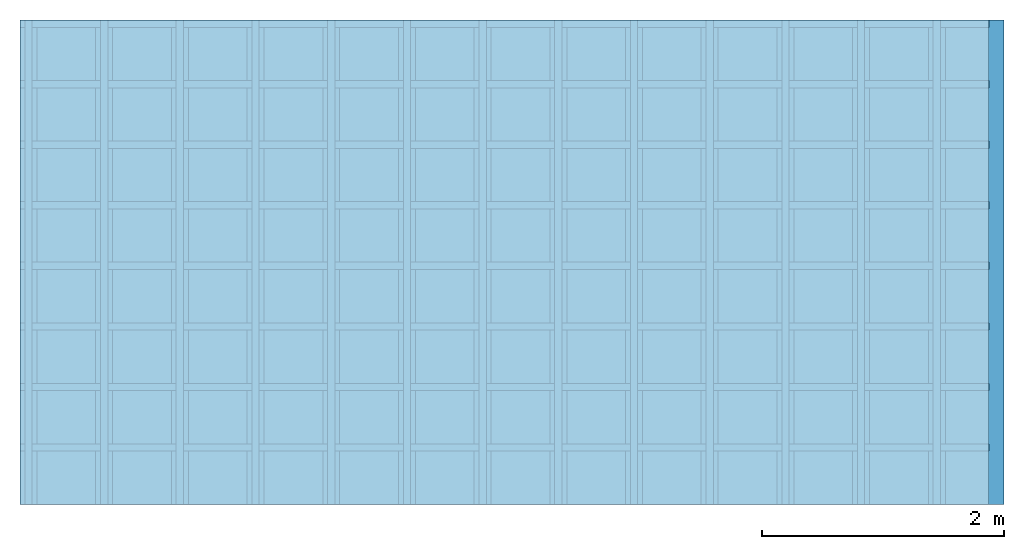
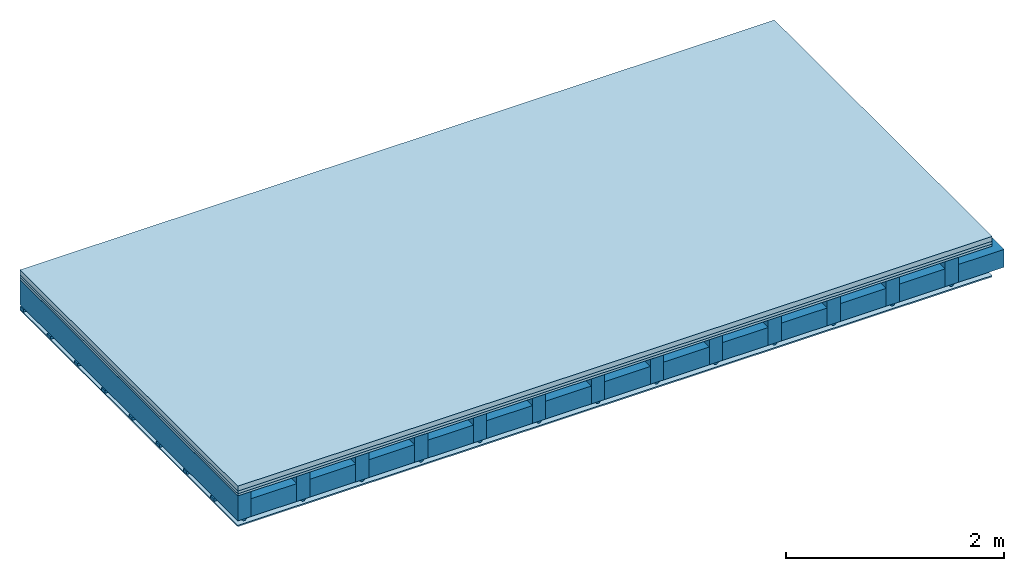
# One storey: 4 members, 4 plates, 1 element without a shape of its own.
"""IFC4 building model written with IfcOpenShell, lengths in metres."""

from ifc_helpers import new_model, si_unit, derived_unit, direction, frame, frame_2d, origin, origin_with_axes, place, context, project, spatial, polyline, rectangle, outline, extrude, material, layer, layer_set, type_object, element, aggregate, save


model = new_model("IFC4")

# Units and contexts
plan_context = context("Plan", 3, precision=1e-05, world=origin(), true_north=direction((0.0, 1.0)))
model_context = context("Model", 3, precision=1e-05, world=origin(), true_north=direction((0.0, 1.0)))
ifc_project = project(units=[si_unit("LENGTHUNIT", "METRE"), derived_unit("SOUNDPRESSUREUNIT", [(si_unit("PRESSUREUNIT", "PASCAL", prefix="MICRO"), 0)]), si_unit("ENERGYUNIT", "JOULE", prefix="MEGA"), si_unit("MASSUNIT", "GRAM", prefix="KILO"), derived_unit("THERMALTRANSMITTANCEUNIT", [(si_unit("POWERUNIT", "WATT"), 1), (si_unit("AREAUNIT", "SQUARE_METRE"), -1), (si_unit("THERMODYNAMICTEMPERATUREUNIT", "KELVIN"), -1)]), derived_unit("AREADENSITYUNIT", [(si_unit("MASSUNIT", "GRAM", prefix="KILO"), 1), (si_unit("AREAUNIT", "SQUARE_METRE"), -1)]), derived_unit("USERDEFINED", [(si_unit("ENERGYUNIT", "JOULE", prefix="MEGA"), 1), (si_unit("AREAUNIT", "SQUARE_METRE"), -1)])], contexts=[plan_context, model_context])

# Site, building, storey
site = spatial("IfcSite", under=ifc_project)
building_placement = place(None, origin())
building = spatial("IfcBuilding", under=site, at=building_placement)
storey_placement = place(building_placement, origin())
storey = spatial("IfcBuildingStorey", under=building, at=storey_placement)

# Slab, members, plates
ifc_material_1 = material(Category="04.005")
ifc_layer_1 = layer(ifc_material_1, 0.055, Name="On-material")
ifc_material_2 = material()
ifc_layer_2 = layer(ifc_material_2, 0.03, Name="Impact sound insulation")
ifc_material_3 = material(Category="07.001")
ifc_layer_3 = layer(ifc_material_3, 0.025, Name="Sub-floor")
ifc_material_4 = material(Name="of the art")
ifc_layer_4 = layer(ifc_material_4, 0.0, Name="Bond")
ifc_layer_5 = layer(None, 0.28, Name="Supporting structure")
ifc_material_5 = material(Name="no composite action")
ifc_layer_6 = layer(ifc_material_5, 0.0, Name="Bond")
ifc_layer_7 = layer(None, 0.02, Name="Coupling")
ifc_layer_8 = layer(None, 0.03, Name="Battens / profiles")
ifc_material_6 = material(Category="03.007")
ifc_layer_9 = layer(ifc_material_6, 0.015, Name="Ceiling covering 1st layer")
ifc_material_7 = material(Name="Glued joints")
ifc_layer_10 = layer(ifc_material_7, 0.0, Name="Surface / treatment")
ifc_layer_set = layer_set([ifc_layer_1, ifc_layer_2, ifc_layer_3, ifc_layer_4, ifc_layer_5, ifc_layer_6, ifc_layer_7, ifc_layer_8, ifc_layer_9, ifc_layer_10])
slab_type = type_object("IfcSlabType", Name="A0122", PredefinedType="NOTDEFINED", material=ifc_layer_set)
slab_placement = place(None, frame((0.0, 0.0, 0.0), z_axis=(0.0, 0.0, -1.0), x_axis=(1.0, 0.0, 0.0)))
slab = element("IfcSlab", 1, at=slab_placement, inside=storey, type_object=slab_type, material=ifc_layer_set, Name="Slab #1")
ifc_material_8 = material()
member_1_placement = place(slab_placement, origin())
member_1 = element("IfcMember", 2, at=member_1_placement, material=ifc_material_8, Name="Supporting structure", context=plan_context, shape_type="SweptSolid", body=[
    extrude(rectangle(XDim=0.14, YDim=0.28, at=frame_2d((0.07, 0.14), x_axis=(1.0, 0.0))), frame((0.0, 4.0, 0.11), z_axis=(0.0, -1.0, 0.0), x_axis=(1.0, 0.0, 0.0)), (0.0, 0.0, 1.0), 4.0),
    extrude(rectangle(XDim=0.14, YDim=0.28, at=frame_2d((0.07, 0.14), x_axis=(1.0, 0.0))), frame((0.625, 4.0, 0.11), z_axis=(0.0, -1.0, 0.0), x_axis=(1.0, 0.0, 0.0)), (0.0, 0.0, 1.0), 4.0),
    extrude(rectangle(XDim=0.14, YDim=0.28, at=frame_2d((0.07, 0.14), x_axis=(1.0, 0.0))), frame((1.25, 4.0, 0.11), z_axis=(0.0, -1.0, 0.0), x_axis=(1.0, 0.0, 0.0)), (0.0, 0.0, 1.0), 4.0),
    extrude(rectangle(XDim=0.14, YDim=0.28, at=frame_2d((0.07, 0.14), x_axis=(1.0, 0.0))), frame((1.875, 4.0, 0.11), z_axis=(0.0, -1.0, 0.0), x_axis=(1.0, 0.0, 0.0)), (0.0, 0.0, 1.0), 4.0),
    extrude(rectangle(XDim=0.14, YDim=0.28, at=frame_2d((0.07, 0.14), x_axis=(1.0, 0.0))), frame((2.5, 4.0, 0.11), z_axis=(0.0, -1.0, 0.0), x_axis=(1.0, 0.0, 0.0)), (0.0, 0.0, 1.0), 4.0),
    extrude(rectangle(XDim=0.14, YDim=0.28, at=frame_2d((0.07, 0.14), x_axis=(1.0, 0.0))), frame((3.125, 4.0, 0.11), z_axis=(0.0, -1.0, 0.0), x_axis=(1.0, 0.0, 0.0)), (0.0, 0.0, 1.0), 4.0),
    extrude(rectangle(XDim=0.14, YDim=0.28, at=frame_2d((0.07, 0.14), x_axis=(1.0, 0.0))), frame((3.75, 4.0, 0.11), z_axis=(0.0, -1.0, 0.0), x_axis=(1.0, 0.0, 0.0)), (0.0, 0.0, 1.0), 4.0),
    extrude(rectangle(XDim=0.14, YDim=0.28, at=frame_2d((0.07, 0.14), x_axis=(1.0, 0.0))), frame((4.375, 4.0, 0.11), z_axis=(0.0, -1.0, 0.0), x_axis=(1.0, 0.0, 0.0)), (0.0, 0.0, 1.0), 4.0),
    extrude(rectangle(XDim=0.14, YDim=0.28, at=frame_2d((0.07, 0.14), x_axis=(1.0, 0.0))), frame((5.0, 4.0, 0.11), z_axis=(0.0, -1.0, 0.0), x_axis=(1.0, 0.0, 0.0)), (0.0, 0.0, 1.0), 4.0),
    extrude(rectangle(XDim=0.14, YDim=0.28, at=frame_2d((0.07, 0.14), x_axis=(1.0, 0.0))), frame((5.625, 4.0, 0.11), z_axis=(0.0, -1.0, 0.0), x_axis=(1.0, 0.0, 0.0)), (0.0, 0.0, 1.0), 4.0),
    extrude(rectangle(XDim=0.14, YDim=0.28, at=frame_2d((0.07, 0.14), x_axis=(1.0, 0.0))), frame((6.25, 4.0, 0.11), z_axis=(0.0, -1.0, 0.0), x_axis=(1.0, 0.0, 0.0)), (0.0, 0.0, 1.0), 4.0),
    extrude(rectangle(XDim=0.14, YDim=0.28, at=frame_2d((0.07, 0.14), x_axis=(1.0, 0.0))), frame((6.875, 4.0, 0.11), z_axis=(0.0, -1.0, 0.0), x_axis=(1.0, 0.0, 0.0)), (0.0, 0.0, 1.0), 4.0),
    extrude(rectangle(XDim=0.14, YDim=0.28, at=frame_2d((0.07, 0.14), x_axis=(1.0, 0.0))), frame((7.5, 4.0, 0.11), z_axis=(0.0, -1.0, 0.0), x_axis=(1.0, 0.0, 0.0)), (0.0, 0.0, 1.0), 4.0),
])
ifc_material_9 = material()
member_2_placement = place(slab_placement, origin())
member_2 = element("IfcMember", 3, at=member_2_placement, material=ifc_material_9, Name="Cavity", context=plan_context, shape_type="SweptSolid", body=[
    extrude(rectangle(XDim=0.485, YDim=0.2, at=frame_2d((0.2425, 0.1), x_axis=(1.0, 0.0))), frame((0.14, 4.0, 0.19), z_axis=(0.0, -1.0, 0.0), x_axis=(1.0, 0.0, 0.0)), (0.0, 0.0, 1.0), 4.0),
    extrude(rectangle(XDim=0.485, YDim=0.2, at=frame_2d((0.2425, 0.1), x_axis=(1.0, 0.0))), frame((0.765, 4.0, 0.19), z_axis=(0.0, -1.0, 0.0), x_axis=(1.0, 0.0, 0.0)), (0.0, 0.0, 1.0), 4.0),
    extrude(rectangle(XDim=0.485, YDim=0.2, at=frame_2d((0.2425, 0.1), x_axis=(1.0, 0.0))), frame((1.39, 4.0, 0.19), z_axis=(0.0, -1.0, 0.0), x_axis=(1.0, 0.0, 0.0)), (0.0, 0.0, 1.0), 4.0),
    extrude(rectangle(XDim=0.485, YDim=0.2, at=frame_2d((0.2425, 0.1), x_axis=(1.0, 0.0))), frame((2.015, 4.0, 0.19), z_axis=(0.0, -1.0, 0.0), x_axis=(1.0, 0.0, 0.0)), (0.0, 0.0, 1.0), 4.0),
    extrude(rectangle(XDim=0.485, YDim=0.2, at=frame_2d((0.2425, 0.1), x_axis=(1.0, 0.0))), frame((2.64, 4.0, 0.19), z_axis=(0.0, -1.0, 0.0), x_axis=(1.0, 0.0, 0.0)), (0.0, 0.0, 1.0), 4.0),
    extrude(rectangle(XDim=0.485, YDim=0.2, at=frame_2d((0.2425, 0.1), x_axis=(1.0, 0.0))), frame((3.265, 4.0, 0.19), z_axis=(0.0, -1.0, 0.0), x_axis=(1.0, 0.0, 0.0)), (0.0, 0.0, 1.0), 4.0),
    extrude(rectangle(XDim=0.485, YDim=0.2, at=frame_2d((0.2425, 0.1), x_axis=(1.0, 0.0))), frame((3.89, 4.0, 0.19), z_axis=(0.0, -1.0, 0.0), x_axis=(1.0, 0.0, 0.0)), (0.0, 0.0, 1.0), 4.0),
    extrude(rectangle(XDim=0.485, YDim=0.2, at=frame_2d((0.2425, 0.1), x_axis=(1.0, 0.0))), frame((4.515, 4.0, 0.19), z_axis=(0.0, -1.0, 0.0), x_axis=(1.0, 0.0, 0.0)), (0.0, 0.0, 1.0), 4.0),
    extrude(rectangle(XDim=0.485, YDim=0.2, at=frame_2d((0.2425, 0.1), x_axis=(1.0, 0.0))), frame((5.14, 4.0, 0.19), z_axis=(0.0, -1.0, 0.0), x_axis=(1.0, 0.0, 0.0)), (0.0, 0.0, 1.0), 4.0),
    extrude(rectangle(XDim=0.485, YDim=0.2, at=frame_2d((0.2425, 0.1), x_axis=(1.0, 0.0))), frame((5.765, 4.0, 0.19), z_axis=(0.0, -1.0, 0.0), x_axis=(1.0, 0.0, 0.0)), (0.0, 0.0, 1.0), 4.0),
    extrude(rectangle(XDim=0.485, YDim=0.2, at=frame_2d((0.2425, 0.1), x_axis=(1.0, 0.0))), frame((6.39, 4.0, 0.19), z_axis=(0.0, -1.0, 0.0), x_axis=(1.0, 0.0, 0.0)), (0.0, 0.0, 1.0), 4.0),
    extrude(rectangle(XDim=0.485, YDim=0.2, at=frame_2d((0.2425, 0.1), x_axis=(1.0, 0.0))), frame((7.015, 4.0, 0.19), z_axis=(0.0, -1.0, 0.0), x_axis=(1.0, 0.0, 0.0)), (0.0, 0.0, 1.0), 4.0),
    extrude(rectangle(XDim=0.485, YDim=0.2, at=frame_2d((0.2425, 0.1), x_axis=(1.0, 0.0))), frame((7.64, 4.0, 0.19), z_axis=(0.0, -1.0, 0.0), x_axis=(1.0, 0.0, 0.0)), (0.0, 0.0, 1.0), 4.0),
])
ifc_material_10 = material()
member_3_placement = place(slab_placement, origin())
member_3 = element("IfcMember", 4, at=member_3_placement, material=ifc_material_10, Name="Coupling", context=plan_context, shape_type="SweptSolid", body=[
    extrude(outline(polyline([(0.0, 0.0), (0.06, 0.0), (0.04, 0.02), (0.02, 0.02), (0.0, 0.0)])), frame((0.04, 4.0, 0.39), z_axis=(0.0, -1.0, 0.0), x_axis=(1.0, 0.0, 0.0)), (0.0, 0.0, 1.0), 4.0),
    extrude(outline(polyline([(0.0, 0.0), (0.06, 0.0), (0.04, 0.02), (0.02, 0.02), (0.0, 0.0)])), frame((0.665, 4.0, 0.39), z_axis=(0.0, -1.0, 0.0), x_axis=(1.0, 0.0, 0.0)), (0.0, 0.0, 1.0), 4.0),
    extrude(outline(polyline([(0.0, 0.0), (0.06, 0.0), (0.04, 0.02), (0.02, 0.02), (0.0, 0.0)])), frame((1.29, 4.0, 0.39), z_axis=(0.0, -1.0, 0.0), x_axis=(1.0, 0.0, 0.0)), (0.0, 0.0, 1.0), 4.0),
    extrude(outline(polyline([(0.0, 0.0), (0.06, 0.0), (0.04, 0.02), (0.02, 0.02), (0.0, 0.0)])), frame((1.915, 4.0, 0.39), z_axis=(0.0, -1.0, 0.0), x_axis=(1.0, 0.0, 0.0)), (0.0, 0.0, 1.0), 4.0),
    extrude(outline(polyline([(0.0, 0.0), (0.06, 0.0), (0.04, 0.02), (0.02, 0.02), (0.0, 0.0)])), frame((2.54, 4.0, 0.39), z_axis=(0.0, -1.0, 0.0), x_axis=(1.0, 0.0, 0.0)), (0.0, 0.0, 1.0), 4.0),
    extrude(outline(polyline([(0.0, 0.0), (0.06, 0.0), (0.04, 0.02), (0.02, 0.02), (0.0, 0.0)])), frame((3.165, 4.0, 0.39), z_axis=(0.0, -1.0, 0.0), x_axis=(1.0, 0.0, 0.0)), (0.0, 0.0, 1.0), 4.0),
    extrude(outline(polyline([(0.0, 0.0), (0.06, 0.0), (0.04, 0.02), (0.02, 0.02), (0.0, 0.0)])), frame((3.79, 4.0, 0.39), z_axis=(0.0, -1.0, 0.0), x_axis=(1.0, 0.0, 0.0)), (0.0, 0.0, 1.0), 4.0),
    extrude(outline(polyline([(0.0, 0.0), (0.06, 0.0), (0.04, 0.02), (0.02, 0.02), (0.0, 0.0)])), frame((4.415, 4.0, 0.39), z_axis=(0.0, -1.0, 0.0), x_axis=(1.0, 0.0, 0.0)), (0.0, 0.0, 1.0), 4.0),
    extrude(outline(polyline([(0.0, 0.0), (0.06, 0.0), (0.04, 0.02), (0.02, 0.02), (0.0, 0.0)])), frame((5.04, 4.0, 0.39), z_axis=(0.0, -1.0, 0.0), x_axis=(1.0, 0.0, 0.0)), (0.0, 0.0, 1.0), 4.0),
    extrude(outline(polyline([(0.0, 0.0), (0.06, 0.0), (0.04, 0.02), (0.02, 0.02), (0.0, 0.0)])), frame((5.665, 4.0, 0.39), z_axis=(0.0, -1.0, 0.0), x_axis=(1.0, 0.0, 0.0)), (0.0, 0.0, 1.0), 4.0),
    extrude(outline(polyline([(0.0, 0.0), (0.06, 0.0), (0.04, 0.02), (0.02, 0.02), (0.0, 0.0)])), frame((6.29, 4.0, 0.39), z_axis=(0.0, -1.0, 0.0), x_axis=(1.0, 0.0, 0.0)), (0.0, 0.0, 1.0), 4.0),
    extrude(outline(polyline([(0.0, 0.0), (0.06, 0.0), (0.04, 0.02), (0.02, 0.02), (0.0, 0.0)])), frame((6.915, 4.0, 0.39), z_axis=(0.0, -1.0, 0.0), x_axis=(1.0, 0.0, 0.0)), (0.0, 0.0, 1.0), 4.0),
    extrude(outline(polyline([(0.0, 0.0), (0.06, 0.0), (0.04, 0.02), (0.02, 0.02), (0.0, 0.0)])), frame((7.54, 4.0, 0.39), z_axis=(0.0, -1.0, 0.0), x_axis=(1.0, 0.0, 0.0)), (0.0, 0.0, 1.0), 4.0),
])
ifc_material_11 = material()
member_4_placement = place(slab_placement, origin())
member_4 = element("IfcMember", 5, at=member_4_placement, material=ifc_material_11, Name="Battens / profiles", context=plan_context, shape_type="SweptSolid", body=[
    extrude(rectangle(XDim=0.06, YDim=0.03, at=frame_2d((0.03, 0.015), x_axis=(1.0, 0.0))), frame((0.0, 0.0, 0.41), z_axis=(1.0, 0.0, 0.0), x_axis=(0.0, 1.0, 0.0)), (0.0, 0.0, 1.0), 8.0),
    extrude(rectangle(XDim=0.06, YDim=0.03, at=frame_2d((0.03, 0.015), x_axis=(1.0, 0.0))), frame((0.0, 0.5, 0.41), z_axis=(1.0, 0.0, 0.0), x_axis=(0.0, 1.0, 0.0)), (0.0, 0.0, 1.0), 8.0),
    extrude(rectangle(XDim=0.06, YDim=0.03, at=frame_2d((0.03, 0.015), x_axis=(1.0, 0.0))), frame((0.0, 1.0, 0.41), z_axis=(1.0, 0.0, 0.0), x_axis=(0.0, 1.0, 0.0)), (0.0, 0.0, 1.0), 8.0),
    extrude(rectangle(XDim=0.06, YDim=0.03, at=frame_2d((0.03, 0.015), x_axis=(1.0, 0.0))), frame((0.0, 1.5, 0.41), z_axis=(1.0, 0.0, 0.0), x_axis=(0.0, 1.0, 0.0)), (0.0, 0.0, 1.0), 8.0),
    extrude(rectangle(XDim=0.06, YDim=0.03, at=frame_2d((0.03, 0.015), x_axis=(1.0, 0.0))), frame((0.0, 2.0, 0.41), z_axis=(1.0, 0.0, 0.0), x_axis=(0.0, 1.0, 0.0)), (0.0, 0.0, 1.0), 8.0),
    extrude(rectangle(XDim=0.06, YDim=0.03, at=frame_2d((0.03, 0.015), x_axis=(1.0, 0.0))), frame((0.0, 2.5, 0.41), z_axis=(1.0, 0.0, 0.0), x_axis=(0.0, 1.0, 0.0)), (0.0, 0.0, 1.0), 8.0),
    extrude(rectangle(XDim=0.06, YDim=0.03, at=frame_2d((0.03, 0.015), x_axis=(1.0, 0.0))), frame((0.0, 3.0, 0.41), z_axis=(1.0, 0.0, 0.0), x_axis=(0.0, 1.0, 0.0)), (0.0, 0.0, 1.0), 8.0),
    extrude(rectangle(XDim=0.06, YDim=0.03, at=frame_2d((0.03, 0.015), x_axis=(1.0, 0.0))), frame((0.0, 3.5, 0.41), z_axis=(1.0, 0.0, 0.0), x_axis=(0.0, 1.0, 0.0)), (0.0, 0.0, 1.0), 8.0),
])
plate_1_placement = place(slab_placement, origin())
plate_1 = element("IfcPlate", 6, at=plate_1_placement, material=ifc_material_1, Name="On-material", context=plan_context, shape_type="SweptSolid", body=[
    extrude(rectangle(XDim=8.0, YDim=4.0, at=frame_2d((4.0, 2.0), x_axis=(1.0, 0.0))), origin_with_axes(), (0.0, 0.0, 1.0), 0.055),
])
plate_2_placement = place(slab_placement, origin())
plate_2 = element("IfcPlate", 7, at=plate_2_placement, material=ifc_material_2, Name="Impact sound insulation", context=plan_context, shape_type="SweptSolid", body=[
    extrude(rectangle(XDim=8.0, YDim=4.0, at=frame_2d((4.0, 2.0), x_axis=(1.0, 0.0))), frame((0.0, 0.0, 0.055), z_axis=(0.0, 0.0, 1.0), x_axis=(1.0, 0.0, 0.0)), (0.0, 0.0, 1.0), 0.03),
])
plate_3_placement = place(slab_placement, origin())
plate_3 = element("IfcPlate", 8, at=plate_3_placement, material=ifc_material_3, Name="Sub-floor", context=plan_context, shape_type="SweptSolid", body=[
    extrude(rectangle(XDim=8.0, YDim=4.0, at=frame_2d((4.0, 2.0), x_axis=(1.0, 0.0))), frame((0.0, 0.0, 0.085), z_axis=(0.0, 0.0, 1.0), x_axis=(1.0, 0.0, 0.0)), (0.0, 0.0, 1.0), 0.025),
])
plate_4_placement = place(slab_placement, origin())
plate_4 = element("IfcPlate", 9, at=plate_4_placement, material=ifc_material_6, Name="Ceiling covering 1st layer", context=plan_context, shape_type="SweptSolid", body=[
    extrude(rectangle(XDim=8.0, YDim=4.0, at=frame_2d((4.0, 2.0), x_axis=(1.0, 0.0))), frame((0.0, 0.0, 0.44), z_axis=(0.0, 0.0, 1.0), x_axis=(1.0, 0.0, 0.0)), (0.0, 0.0, 1.0), 0.015),
])
aggregate(slab, [plate_1, plate_2, plate_3, member_1, member_2, member_3, member_4, plate_4])

save(model, "model.ifc")
